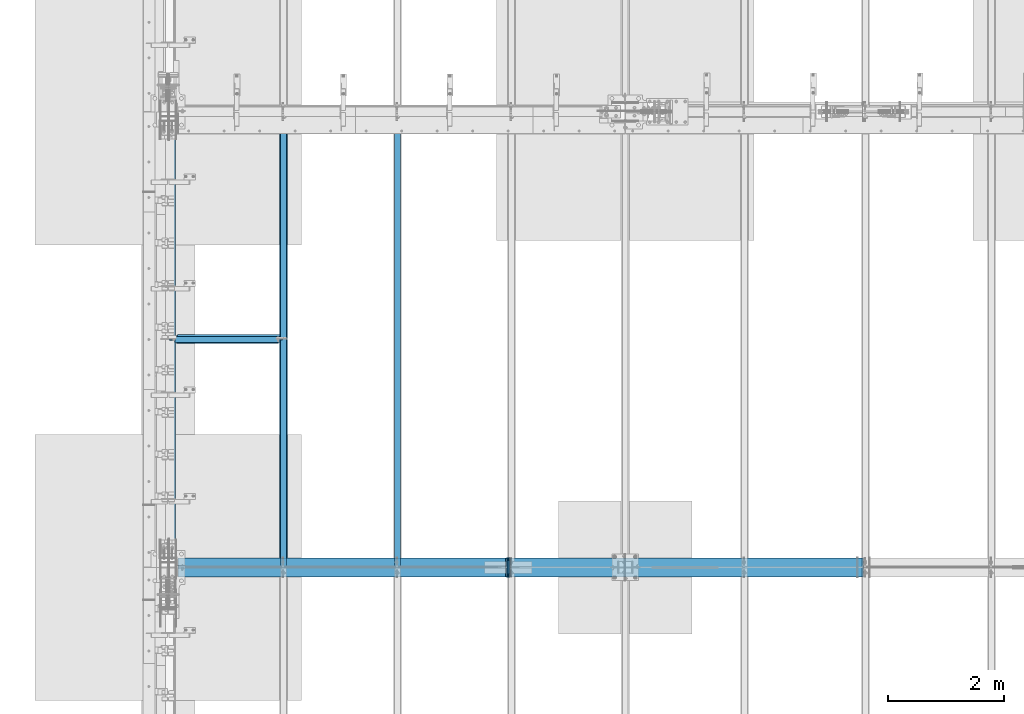
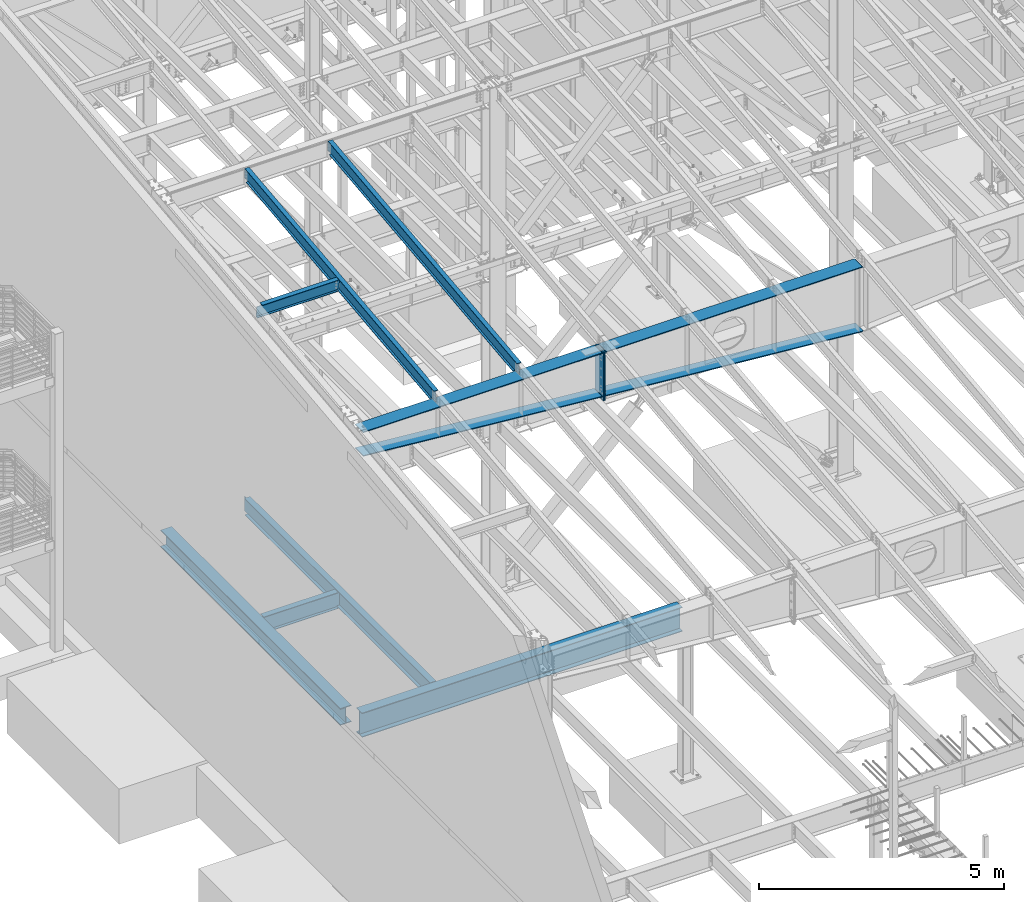
# One storey, part 726 of 1179: 13 beams, 9 elements without a shape of their own.
"""IFC2X3 building model written with IfcOpenShell, lengths in millimetres."""

from ifc_helpers import new_model, si_unit, frame, origin_with_axes, place, context, subcontext, project, spatial, faceted_brep, material, type_object, element, aggregate, save


model = new_model("IFC2X3")

# Units and contexts
model_context = context("Model", 3, precision=1e-05, world=origin_with_axes())
body_context = subcontext(model_context, "Body", "Model", "MODEL_VIEW")
ifc_project = project(units=[si_unit("LENGTHUNIT", "METRE", prefix="MILLI"), si_unit("AREAUNIT", "SQUARE_METRE"), si_unit("VOLUMEUNIT", "CUBIC_METRE"), si_unit("MASSUNIT", "GRAM", prefix="KILO"), si_unit("TIMEUNIT", "SECOND"), si_unit("PLANEANGLEUNIT", "RADIAN"), si_unit("SOLIDANGLEUNIT", "STERADIAN"), si_unit("THERMODYNAMICTEMPERATUREUNIT", "DEGREE_CELSIUS"), si_unit("LUMINOUSINTENSITYUNIT", "LUMEN")], contexts=[model_context])

# Site, building, storey
site_placement = place(None, origin_with_axes())
site = spatial("IfcSite", under=ifc_project, at=site_placement, CompositionType="ELEMENT")
building_placement = place(site_placement, origin_with_axes())
building = spatial("IfcBuilding", under=site, at=building_placement, Name="Undefined", CompositionType="ELEMENT")
storey_placement = place(building_placement, origin_with_axes())
storey = spatial("IfcBuildingStorey", under=building, at=storey_placement, Name="Undefined", CompositionType="ELEMENT", Elevation=0.0)

# Assembly, beam
assembly_1_placement = place(storey_placement, origin_with_axes())
assembly_1 = element("IfcElementAssembly", 1, at=assembly_1_placement, inside=storey, Name="BEAM", AssemblyPlace="NOTDEFINED", PredefinedType="RIGID_FRAME")
ifc_material_1 = material(Name="STEEL/A992")
beam_type_1 = type_object("IfcBeamType", Name="W16X31", PredefinedType="NOTDEFINED")
beam_1_placement = place(assembly_1_placement, frame((431.800000000002, 23139.4, 3900.4875), z_axis=(0.0, 0.0, 1.0), x_axis=(1.0, 0.0, 0.0)))
beam_1 = element("IfcBeam", 2, at=beam_1_placement, type_object=beam_type_1, material=ifc_material_1, Name="BEAM", ObjectType="W16X31", context=body_context, shape_type="Brep", body=[
    faceted_brep([(1898.64985351562, -3.17499999999927, -190.5), (1898.64985351562, -69.8500000000004, -190.5), (1898.64985351562, -69.8500000000004, -201.6125), (1898.64985351562, 69.8500000000004, -201.6125), (1898.64985351562, 69.8500000000004, -190.5), (1898.64985351562, 3.17499999999927, -190.5), (1898.64985351562, 3.17499999999927, -182.562499809264), (1898.64985351562, -3.17499999999927, -182.562499809264), (1899.61658343821, 3.17499999999927, -177.702420291219), (1899.61658343821, -3.17499999999927, -177.702420291219), (1902.36959733869, 3.17499999999927, -173.582243823065), (1902.36959733869, -3.17499999999927, -173.582243823065), (1906.48977380684, 3.17499999999927, -170.829229922587), (1906.48977380684, -3.17499999999927, -170.829229922587), (1911.34985332489, 3.17499999999927, -169.862499999999), (1911.34985332489, -3.17499999999927, -169.862499999999), (1965.32485351562, -3.17499999999927, -169.862499999999), (1965.32485351562, 3.17499999999927, -169.862499999999), (142.081250000001, 3.17499999999927, 190.5), (142.081250000001, 69.8499999999985, 190.5), (1898.64985351562, 69.8500000000004, 190.5), (1898.64985351562, 3.17499999999927, 190.5), (142.08125, -3.17499999999927, -169.862499809266), (142.08125, 3.17499999999927, -169.862499809266), (142.081250000001, 3.17499999999927, -190.5), (142.081250000001, 69.8499999999985, -190.5), (142.081250000001, 69.8499999999985, -201.6125), (142.081250000001, -69.8499999999985, -201.6125), (142.081250000001, -69.8499999999985, -190.5), (142.081250000001, -3.17499999999927, -190.5), (141.114520077412, -3.17499999999927, -165.00242029122), (141.114520077412, 3.17499999999927, -165.00242029122), (138.361506176934, -3.17499999999927, -160.882243823066), (138.361506176934, 3.17499999999927, -160.882243823066), (134.24132970878, -3.17499999999927, -158.129229922588), (134.24132970878, 3.17499999999927, -158.129229922588), (129.381250190735, -3.17499999999927, -157.1625), (129.381250190735, 3.17499999999927, -157.1625), (18.2562499999996, -3.17499999999927, -157.1625), (18.2562499999996, 3.17499999999927, -157.1625), (18.2562499999996, -3.17499999999927, 157.1625), (18.2562499999996, 3.17499999999927, 157.1625), (129.381250190735, -3.17499999999927, 157.1625), (129.381250190735, 3.17499999999927, 157.1625), (134.24132970878, -3.17499999999927, 158.129229922588), (134.24132970878, 3.17499999999927, 158.129229922588), (138.361506176934, -3.17499999999927, 160.882243823066), (138.361506176934, 3.17499999999927, 160.882243823066), (141.114520077412, -3.17499999999927, 165.00242029122), (141.114520077412, 3.17499999999927, 165.00242029122), (142.08125, -3.17499999999927, 169.862499809265), (142.08125, 3.17499999999927, 169.862499809265), (142.081250000001, -69.8499999999985, 201.6125), (142.081250000001, 69.8499999999985, 201.6125), (142.081250000001, -3.17499999999927, 190.5), (142.081250000001, -69.8499999999985, 190.5), (1898.64985351562, -3.17499999999927, 190.5), (1898.64985351562, -69.8500000000004, 190.5), (1898.64985351562, -69.8500000000004, 201.6125), (1898.64985351562, 69.8500000000004, 201.6125), (1898.64985351562, -3.17499999999927, 182.562499809266), (1898.64985351562, 3.17499999999927, 182.562499809266), (1899.61658343821, -3.17499999999927, 177.70242029122), (1899.61658343821, 3.17499999999927, 177.70242029122), (1902.36959733869, -3.17499999999927, 173.582243823067), (1902.36959733869, 3.17499999999927, 173.582243823067), (1906.48977380684, -3.17499999999927, 170.829229922589), (1906.48977380684, 3.17499999999927, 170.829229922589), (1911.34985332489, -3.17499999999927, 169.862500000001), (1911.34985332489, 3.17499999999927, 169.862500000001), (1965.32485351562, -3.17499999999927, 169.862500000001), (1965.32485351562, 3.17499999999927, 169.862500000001)], [[[0, 1, 2, 3, 4, 5, 6, 7]], [[7, 6, 8, 9]], [[9, 8, 10, 11]], [[11, 10, 12, 13]], [[13, 12, 14, 15]], [[16, 15, 14, 17]], [[18, 19, 20, 21]], [[22, 23, 24, 25, 26, 27, 28, 29]], [[30, 31, 23, 22]], [[32, 33, 31, 30]], [[34, 35, 33, 32]], [[36, 37, 35, 34]], [[38, 39, 37, 36]], [[40, 41, 39, 38]], [[42, 43, 41, 40]], [[44, 45, 43, 42]], [[46, 47, 45, 44]], [[48, 49, 47, 46]], [[50, 51, 49, 48]], [[52, 53, 19, 18, 51, 50, 54, 55]], [[55, 54, 56, 57]], [[52, 55, 57, 58]], [[53, 52, 58, 59]], [[19, 53, 59, 20]], [[58, 57, 56, 60, 61, 21, 20, 59]], [[62, 63, 61, 60]], [[64, 65, 63, 62]], [[66, 67, 65, 64]], [[68, 69, 67, 66]], [[70, 71, 69, 68]], [[71, 70, 16, 17]], [[12, 10, 8, 6, 5, 24, 23, 31, 33, 35, 37, 39, 41, 43, 45, 47, 49, 51, 18, 21, 61, 63, 65, 67, 69, 71, 17, 14]], [[25, 24, 5, 4]], [[26, 25, 4, 3]], [[27, 26, 3, 2]], [[28, 27, 2, 1]], [[29, 28, 1, 0]], [[70, 68, 66, 64, 62, 60, 56, 54, 50, 48, 46, 44, 42, 40, 38, 36, 34, 32, 30, 22, 29, 0, 7, 9, 11, 13, 15, 16]]]),
])
aggregate(assembly_1, [beam_1])

assembly_2_placement = place(storey_placement, origin_with_axes())
assembly_2 = element("IfcElementAssembly", 3, at=assembly_2_placement, inside=storey, Name="BEAM", AssemblyPlace="NOTDEFINED", PredefinedType="RIGID_FRAME")
beam_2_placement = place(assembly_2_placement, frame((2412.99985351563, 19227.8, 3900.4875), z_axis=(0.0, 0.0, 1.0), x_axis=(0.0, 1.0, 0.0)))
beam_2 = element("IfcBeam", 4, at=beam_2_placement, type_object=beam_type_1, material=ifc_material_1, Name="BEAM", ObjectType="W16X31", context=body_context, shape_type="Brep", body=[
    faceted_brep([(113.506251936145, -3.17499999997744, 169.8625), (113.506251936145, 3.17496422017757, 169.8625), (18.2562514952835, 3.17499999999927, 169.8625), (18.2562514952835, -3.17499999999927, 169.8625), (118.366331454192, -3.17499999997926, 170.829229922588), (118.366331454192, 3.17496349569046, 170.829229922588), (122.486507922345, -3.17499999997744, 173.582243823066), (122.486507922345, 3.17496143253265, 173.582243823066), (125.239521822827, -3.17499999997563, 177.70242029122), (125.239521822819, 3.17495834479632, 177.70242029122), (126.206251745411, -3.17499999997744, 182.562499809265), (126.206251745411, 3.1749547025629, 182.562499809265), (126.206251745432, -69.8499999999767, 201.6125), (126.206251745396, 69.850000000024, 201.6125), (126.206251745396, 69.850000000024, 190.5), (126.206251745418, 3.17500000002292, 190.5), (126.206251745411, -3.17499999997744, 190.5), (126.206251745432, -69.8499999999767, 190.5), (7677.15000000001, 3.17499999999927, -190.5), (7677.15000000001, 69.8499999999985, -190.5), (145.256250000001, 69.8499999999985, -190.5), (145.256250000001, 3.17549991607666, -190.5), (18.2562500000006, -3.17500000000291, -190.5), (18.2562500000006, -69.8499999999985, -190.5), (7804.15, -69.8499999999985, -190.5), (7804.15, -3.17499999999927, -190.5), (18.2562500000006, -69.8499999999985, -201.612499999999), (7804.15, -69.8499999999985, -201.6125), (7677.15000000001, 69.8499999999985, -201.6125), (7677.15000000001, 3.17549991607666, -201.6125), (7804.15, 3.17549991607666, -201.6125), (18.2562500000006, 3.17549991607666, -201.612499999999), (145.256250000001, 3.17549991607666, -201.612499999999), (145.256250000001, 69.8499999999985, -201.612499999999), (18.2562500000006, 3.17500000000291, -190.5), (7804.15, 3.17499999999927, -190.5), (7804.15, 3.17499999999927, 169.8625), (7804.15, -3.17499999999927, 169.8625), (7708.89999980925, 3.17499999999927, 169.8625), (7708.89999980925, -3.17499999999927, 169.8625), (7704.03992029121, 3.17499999999927, 170.829229922588), (7704.03992029121, -3.17499999999927, 170.829229922588), (7699.91974382305, 3.17499999999927, 173.582243823066), (7699.91974382305, -3.17499999999927, 173.582243823066), (7697.16672992258, 3.17499999999927, 177.70242029122), (7697.16672992258, -3.17499999999927, 177.70242029122), (7696.19999999999, 3.17499999999927, 182.562499809265), (7696.19999999999, -3.17499999999927, 182.562499809265), (7696.19999999999, -69.8499999999985, 201.6125), (7696.19999999999, -69.8499999999985, 190.5), (7696.19999999999, -3.17499999999927, 190.5), (7696.19999999999, 3.17499999999927, 190.5), (7696.19999999999, 69.8499999999985, 190.5), (7696.19999999999, 69.8499999999985, 201.6125)], [[[0, 1, 2, 3]], [[4, 5, 1, 0]], [[6, 7, 5, 4]], [[8, 9, 7, 6]], [[10, 11, 9, 8]], [[12, 13, 14, 15, 11, 10, 16, 17]], [[18, 19, 20, 21]], [[22, 23, 24, 25]], [[23, 26, 27, 24]], [[28, 29, 30, 27, 26, 31, 32, 33]], [[21, 32, 31, 34]], [[20, 33, 32, 21]], [[19, 28, 33, 20]], [[18, 29, 28, 19]], [[35, 30, 29, 18]], [[25, 24, 27, 30, 35, 36, 37]], [[37, 36, 38, 39]], [[39, 38, 40, 41]], [[41, 40, 42, 43]], [[43, 42, 44, 45]], [[45, 44, 46, 47]], [[48, 49, 50, 47, 46, 51, 52, 53]], [[49, 48, 12, 17]], [[50, 49, 17, 16]], [[8, 6, 4, 0, 3, 22, 25, 37, 39, 41, 43, 45, 47, 50, 16, 10]], [[34, 31, 26, 23, 22, 3, 2]], [[51, 46, 44, 42, 40, 38, 36, 35, 18, 21, 34, 2, 1, 5, 7, 9, 11, 15]], [[52, 51, 15, 14]], [[53, 52, 14, 13]], [[48, 53, 13, 12]]]),
])
aggregate(assembly_2, [beam_2])

assembly_3_placement = place(storey_placement, origin_with_axes())
assembly_3 = element("IfcElementAssembly", 5, at=assembly_3_placement, inside=storey, Name="RAFTER BEAM", AssemblyPlace="NOTDEFINED", PredefinedType="RIGID_FRAME")
ifc_material_2 = material(Name="STEEL/A36")
beam_type_2 = type_object("IfcBeamType", PredefinedType="NOTDEFINED")
beam_3_placement = place(assembly_3_placement, frame((6261.1, 19392.8999999987, 10522.74375), z_axis=(0.0, 0.0, 1.0), x_axis=(0.0, -1.0, 0.0)))
beam_3 = element("IfcBeam", 6, at=beam_3_placement, type_object=beam_type_2, material=ifc_material_2, Name="PLATE", context=body_context, shape_type="Brep", body=[
    faceted_brep([(0.0, 12.7000000000007, -604.8375), (0.0, 12.7000000000007, 604.8375), (330.199999998662, 12.7000000000007, 604.8375), (330.199999998662, 12.7000000000007, -604.8375), (0.0, -12.7000000000007, 604.8375), (330.199999998662, -12.7000000000007, 604.8375), (0.0, -12.7000000000007, -604.8375), (330.199999998662, -12.7000000000007, -604.8375)], [[[0, 1, 2, 3]], [[1, 4, 5, 2]], [[4, 6, 7, 5]], [[6, 0, 3, 7]], [[5, 7, 3, 2]], [[6, 4, 1, 0]]]),
])

assembly_4_placement = place(storey_placement, origin_with_axes())
assembly_4 = element("IfcElementAssembly", 7, at=assembly_4_placement, inside=storey, Name="RAFTER BEAM", AssemblyPlace="NOTDEFINED", PredefinedType="RIGID_FRAME")
beam_4_placement = place(assembly_4_placement, frame((6286.5, 19392.8999999987, 10522.74375), z_axis=(0.0, 0.0, 1.0), x_axis=(0.0, -1.0, 0.0)))
beam_4 = element("IfcBeam", 8, at=beam_4_placement, type_object=beam_type_2, material=ifc_material_2, Name="PLATE", context=body_context, shape_type="Brep", body=[
    faceted_brep([(0.0, 12.7000000000007, -604.8375), (0.0, 12.7000000000007, 604.8375), (330.199999998662, 12.7000000000007, 604.8375), (330.199999998662, 12.7000000000007, -604.8375), (0.0, -12.7000000000007, 604.8375), (330.199999998662, -12.7000000000007, 604.8375), (0.0, -12.7000000000007, -604.8375), (330.199999998662, -12.7000000000007, -604.8375)], [[[0, 1, 2, 3]], [[1, 4, 5, 2]], [[4, 6, 7, 5]], [[6, 0, 3, 7]], [[5, 7, 3, 2]], [[6, 4, 1, 0]]]),
])

# Beam
beam_type_3 = type_object("IfcBeamType", PredefinedType="NOTDEFINED")
beam_5_placement = place(assembly_3_placement, frame((600.692587263406, 19227.8, 10529.2164037786), z_axis=(0.0, 1.0, 0.0), x_axis=(0.996183710890709, 0.0, -0.0872812359904244)))
beam_5 = element("IfcBeam", 9, at=beam_5_placement, type_object=beam_type_3, material=ifc_material_2, Name="PLATE", context=body_context, shape_type="Brep", body=[
    faceted_brep([(5670.3221448979, 11.172430163635, 165.1), (5643.908580592, -11.1125000006832, 165.1), (5643.908580592, -11.1125000006832, -165.1), (5670.31689408045, 11.1124999993244, -165.1), (1.66062363859965e-09, -11.1125000000084, -165.1), (1.66062363859965e-09, -11.1125000000084, 165.1), (1.94725676632936, 11.1125000000065, 165.1), (1.94725676632936, 11.1125000000065, -165.1)], [[[0, 1, 2, 3]], [[4, 5, 6, 7]], [[7, 6, 0, 3]], [[4, 7, 3, 2]], [[5, 4, 2, 1]], [[6, 5, 1, 0]]]),
])

beam_6_placement = place(assembly_3_placement, frame((601.662500000002, 19227.7999999987, 11116.4687496185), z_axis=(0.0, -1.0, 0.0), x_axis=(1.0, 0.0, 0.0)))
beam_6 = element("IfcBeam", 10, at=beam_6_placement, type_object=beam_type_3, material=ifc_material_2, Name="PLATE", context=body_context, shape_type="Brep", body=[
    faceted_brep([(5646.7375, -11.1124999999993, 165.1), (5646.7375, -11.1124999999993, -165.1), (5624.51249961853, 11.1124999999993, -165.1), (5624.51249961853, 11.1124999999993, 165.1), (1.66062363859965e-09, -11.1125000000084, -165.1), (1.66062363859965e-09, -11.1125000000084, 165.1), (0.0, 11.1124999999993, 165.1), (0.0, 11.1124999999993, -165.1)], [[[0, 1, 2, 3]], [[4, 5, 6, 7]], [[6, 5, 0, 3]], [[7, 6, 3, 2]], [[4, 7, 2, 1]], [[5, 4, 1, 0]]]),
])

aggregate(assembly_3, [beam_3, beam_5, beam_6])

beam_7_placement = place(assembly_4_placement, frame((6272.85711370745, 19227.8000000028, 10032.2463234305), z_axis=(0.0, 1.0, 0.0), x_axis=(0.996393807714311, 0.0, -0.0848491599756718)))
beam_7 = element("IfcBeam", 11, at=beam_7_placement, type_object=beam_type_3, material=ifc_material_2, Name="PLATE", context=body_context, shape_type="Brep", body=[
    faceted_brep([(6118.06175688711, -11.1260574296557, 165.1), (6118.06324270278, -11.1125000015909, -165.1), (6099.33128163823, 11.1124999984149, -165.1), (6099.33128163823, 11.1124999984149, 165.1), (46.0705669150266, -11.1125236432727, 165.1), (27.3845310142515, 11.112499999992, 165.1), (27.3845310142515, 11.112499999992, -165.1), (46.0705669150275, -11.1125000000138, -165.1)], [[[0, 1, 2, 3]], [[4, 5, 6, 7]], [[5, 4, 0, 3]], [[6, 5, 3, 2]], [[7, 6, 2, 1]], [[4, 7, 1, 0]]]),
])

beam_8_placement = place(assembly_4_placement, frame((6273.8, 19227.7999999987, 11116.4687496185), z_axis=(0.0, -1.0, 0.0), x_axis=(1.0, 0.0, 0.0)))
beam_8 = element("IfcBeam", 12, at=beam_8_placement, type_object=beam_type_3, material=ifc_material_2, Name="PLATE", context=body_context, shape_type="Brep", body=[
    faceted_brep([(47.6250003814685, 11.1125003814705, 165.1), (47.6250003814685, 11.1124999999993, -165.1), (25.3999999999987, -11.1124999999993, -165.1), (25.3999999999987, -11.1124999999993, 165.1), (6096.0, -11.1124999999993, 165.1), (6096.0, -11.1124999999993, -165.1), (6073.77499961853, 11.1124999999993, -165.1), (6073.77499961853, 11.1124999999993, 165.1)], [[[0, 1, 2, 3]], [[4, 5, 6, 7]], [[4, 7, 0, 3]], [[5, 4, 3, 2]], [[6, 5, 2, 1]], [[7, 6, 1, 0]]]),
])

aggregate(assembly_4, [beam_4, beam_7, beam_8])

# Assembly, beam
assembly_5_placement = place(storey_placement, origin_with_axes())
assembly_5 = element("IfcElementAssembly", 13, at=assembly_5_placement, inside=storey, Name="BEAM", AssemblyPlace="NOTDEFINED", PredefinedType="RIGID_FRAME")
beam_type_4 = type_object("IfcBeamType", Name="W12X22", PredefinedType="NOTDEFINED")
beam_9_placement = place(assembly_5_placement, frame((431.800000000002, 23156.8779321476, 11707.011532693), z_axis=(0.0, -0.112284087038017, 0.993676146336441), x_axis=(1.0, 0.0, 0.0)))
beam_9 = element("IfcBeam", 14, at=beam_9_placement, type_object=beam_type_4, material=ifc_material_1, Name="BEAM", ObjectType="W12X22", context=body_context, shape_type="Brep", body=[
    faceted_brep([(1917.7, -3.1750000000502, -144.462499999914), (1917.7, -50.8000000000247, -144.462499999896), (1917.7, -50.8000000000284, -155.574999999892), (1917.7, 50.7999999999156, -155.574999999932), (1917.7, 50.7999999999192, -144.46249999994), (1917.7, 3.17499999869324, -144.462499999918), (1917.7, 3.17499998151106, -142.874999810523), (1917.7, -3.17500000004657, -142.874999810521), (1918.66672992259, 3.17499998191852, -138.014920292486), (1918.66672992259, -3.17500000004657, -138.014920292482), (1921.41974382307, 3.17499998226413, -133.894743824339), (1921.41974382307, -3.17500000004293, -133.894743824334), (1925.53992029122, 3.17499998249332, -131.141729923864), (1925.53992029122, -3.17500000004293, -131.141729923862), (1930.39999980926, 3.17499998257699, -130.175000001278), (1930.39999980926, -3.17500000004293, -130.175000001276), (1965.325, -3.17500000004293, -130.175000001276), (1965.325, 3.17499999995198, -130.175000001278), (121.44375, 3.17500000006476, 144.462499999918), (121.44375, 50.8000000000357, 144.4624999999), (1917.7, 50.8000000000357, 144.4624999999), (1917.7, 3.17500000006476, 144.462499999918), (159.54375, 50.7999999999192, -144.46249999994), (159.54375, 50.7999999999156, -155.574999999932), (159.54375, 3.17499995235266, -155.574999999913), (159.54375, 3.17499995235994, -144.462499999918), (19.8437500000002, 3.17499995235266, -155.574999999913), (19.8437500000002, 3.17499999994834, -144.46249999992), (19.8437500000002, -50.8000000000284, -155.574999999892), (19.8437500000002, -50.8000000000247, -144.462499999896), (19.8437500000002, -3.1750000000502, -144.462499999914), (19.8437500000002, -3.1749999999447, 117.474999998307), (19.8437500000002, 3.17500000005384, 117.474999998303), (108.743750190735, -3.1749999999447, 117.474999998307), (108.743750190735, 3.17500000199652, 117.474999998303), (113.603829708781, -3.1749999999447, 118.441729920891), (113.603829708781, 3.17500000207292, 118.441729920887), (117.724006176934, -3.1749999999447, 121.194743821365), (117.724006176934, 3.17500000229848, 121.194743821363), (120.477020077412, -3.17499999993743, 125.314920289511), (120.477020077412, 3.17500000264045, 125.314920289509), (121.44375, -3.17499999993743, 130.174999807548), (121.44375, 3.17500000304426, 130.174999807547), (121.44375, -50.799999999901, 155.574999999935), (121.44375, 50.8000000000429, 155.574999999893), (121.44375, -3.17499999993379, 144.462499999923), (121.44375, -50.7999999999047, 144.462499999941), (1917.7, -3.17499999993379, 144.462499999923), (1917.7, -50.7999999999047, 144.462499999941), (1917.7, -50.799999999901, 155.574999999935), (1917.7, 50.8000000000429, 155.574999999893), (1917.7, -3.17499999993015, 142.874999807531), (1917.7, 3.17500000523796, 142.874999807529), (1918.66672992259, -3.17499999993379, 138.014920289494), (1918.66672992259, 3.17500000483415, 138.01492028949), (1921.41974382307, -3.17499999993743, 133.894743821347), (1921.41974382307, 3.17500000449218, 133.894743821345), (1925.53992029122, -3.17499999993379, 131.141729920873), (1925.53992029122, 3.17500000425935, 131.141729920872), (1930.39999980926, -3.17499999994106, 130.174999998288), (1930.39999980926, 3.17500000417931, 130.174999998286), (1965.325, -3.17499999994106, 130.174999998288), (1965.325, 3.17500000005748, 130.174999998284)], [[[0, 1, 2, 3, 4, 5, 6, 7]], [[7, 6, 8, 9]], [[9, 8, 10, 11]], [[11, 10, 12, 13]], [[13, 12, 14, 15]], [[16, 15, 14, 17]], [[18, 19, 20, 21]], [[22, 23, 24, 25]], [[25, 24, 26, 27]], [[27, 26, 28, 29, 30, 31, 32]], [[33, 34, 32, 31]], [[35, 36, 34, 33]], [[37, 38, 36, 35]], [[39, 40, 38, 37]], [[41, 42, 40, 39]], [[43, 44, 19, 18, 42, 41, 45, 46]], [[46, 45, 47, 48]], [[43, 46, 48, 49]], [[44, 43, 49, 50]], [[19, 44, 50, 20]], [[49, 48, 47, 51, 52, 21, 20, 50]], [[53, 54, 52, 51]], [[55, 56, 54, 53]], [[57, 58, 56, 55]], [[59, 60, 58, 57]], [[61, 62, 60, 59]], [[62, 61, 16, 17]], [[12, 10, 8, 6, 5, 25, 27, 32, 34, 36, 38, 40, 42, 18, 21, 52, 54, 56, 58, 60, 62, 17, 14]], [[22, 25, 5, 4]], [[23, 22, 4, 3]], [[28, 26, 24, 23, 3, 2]], [[29, 28, 2, 1]], [[30, 29, 1, 0]], [[61, 59, 57, 55, 53, 51, 47, 45, 41, 39, 37, 35, 33, 31, 30, 0, 7, 9, 11, 13, 15, 16]]]),
])
aggregate(assembly_5, [beam_9])

assembly_6_placement = place(storey_placement, origin_with_axes())
assembly_6 = element("IfcElementAssembly", 15, at=assembly_6_placement, inside=storey, Name="BEAM", AssemblyPlace="NOTDEFINED", PredefinedType="RIGID_FRAME")
beam_10_placement = place(assembly_6_placement, frame((4368.8, 19245.2779321397, 11265.0059190149), z_axis=(0.0, -0.112284087038017, 0.993676146336441), x_axis=(0.0, 0.993676146336441, 0.112284087038017)))
beam_10 = element("IfcBeam", 16, at=beam_10_placement, type_object=beam_type_4, material=ifc_material_1, Name="BEAM", ObjectType="W12X22", context=body_context, shape_type="Brep", body=[
    faceted_brep([(7676.8057846648, 3.17499999999927, -144.462500003032), (7676.80578466482, 3.17490308365814, -155.575000003026), (7676.80577856895, 50.7999999999993, -155.575000003026), (7676.80577856896, 50.7999999999993, -144.462500003034), (7820.7019525921, 3.17499999999927, -144.462500003092), (7819.44625482597, 3.17492134140048, -155.575000003084), (5.12531926095107, 3.17499999999927, 144.46249999992), (5.12531926095107, 50.7999999999993, 144.46249999992), (7757.4939140051, 50.7999999999993, 144.462499996773), (7757.4939140051, 3.17499999999927, 144.462499996773), (5.12531926095107, -3.17499999999927, 144.46249999992), (5.12531926095107, -50.7999999999993, 144.46249999992), (6.38101702707718, -50.7999999999993, 155.574999999912), (6.38101702707718, 50.7999999999993, 155.574999999912), (-25.0621566261689, 3.17499999999927, -122.686438896275), (-25.0621566261689, -3.17499999999927, -122.686438896275), (145.312894957096, 3.17499999999927, -141.93859400049), (145.312894957096, -3.17499999999927, -141.93859400049), (145.027696926005, -3.17499999999927, -144.462499999976), (145.027696926005, -50.7999999999993, -144.462499999976), (7676.805791578, -50.7999999999993, -144.462500003034), (7676.805785482, -3.17499999999927, -144.462500003032), (145.027696926005, 3.17499999999927, -144.462499999976), (145.027696926005, 50.7999999999993, -144.462499999976), (143.771999161854, 50.7999999999993, -155.574999999972), (143.771999161854, -50.7999999999993, -155.574999999972), (7676.805791578, -50.7999999999993, -155.575000003026), (7676.80578548203, -3.17509692720705, -155.575000003026), (7820.7019525921, -3.17499999999927, -144.462500003092), (7819.44625482597, -3.17507866903179, -155.575000003084), (7760.28182167741, -3.17499999999927, 99.3123538561285), (7756.49682025474, -3.17499999999927, 102.510588352729), (7754.22384626446, -3.17499999999927, 106.91382908024), (7753.80893939206, -3.17499999999927, 111.851722553385), (7757.4939140051, -3.17499999999927, 144.462499996773), (7821.50556176969, -3.17499999999927, -137.350830916108), (7847.03058449439, -3.17499999999927, 88.5369763886902), (7765.00261837702, -3.17499999999927, 97.8060278004923), (7757.4939140051, -50.7999999999993, 144.462499996773), (7758.74961177122, -50.7999999999993, 155.574999996767), (7758.74961177122, 50.7999999999993, 155.574999996767), (7753.80893939206, 3.17499999999927, 111.851722553385), (7754.22384626446, 3.17499999999927, 106.91382908024), (7756.49682025474, 3.17499999999927, 102.510588352729), (7760.28182167741, 3.17499999999927, 99.3123538561285), (7765.00261837702, 3.17499999999927, 97.8060278004923), (7847.03058449439, 3.17499999999927, 88.5369763886902), (7821.50554925474, 3.17499999999927, -137.350941669098)], [[[0, 1, 2, 3]], [[4, 5, 1, 0]], [[6, 7, 8, 9]], [[10, 11, 12, 13, 7, 6, 14, 15]], [[15, 14, 16, 17]], [[18, 19, 20, 21]], [[17, 16, 22, 23, 24, 25, 19, 18]], [[19, 25, 26, 20]], [[20, 26, 27, 21]], [[28, 21, 27, 29]], [[30, 31, 32, 33, 34, 10, 15, 17, 18, 21, 28, 35, 36, 37]], [[11, 10, 34, 38]], [[12, 11, 38, 39]], [[13, 12, 39, 40]], [[7, 13, 40, 8]], [[39, 38, 34, 33, 41, 9, 8, 40]], [[32, 42, 41, 33]], [[31, 43, 42, 32]], [[30, 44, 43, 31]], [[37, 45, 44, 30]], [[36, 46, 45, 37]], [[47, 4, 0, 22, 16, 14, 6, 9, 41, 42, 43, 44, 45, 46]], [[23, 22, 0, 3]], [[24, 23, 3, 2]], [[29, 27, 26, 25, 24, 2, 1, 5]], [[47, 46, 36, 35, 28, 29, 5, 4]]]),
])
aggregate(assembly_6, [beam_10])

assembly_7_placement = place(storey_placement, origin_with_axes())
assembly_7 = element("IfcElementAssembly", 17, at=assembly_7_placement, inside=storey, Name="BEAM", AssemblyPlace="NOTDEFINED", PredefinedType="RIGID_FRAME")
beam_11_placement = place(assembly_7_placement, frame((2413.0, 19245.2779321397, 11265.0059190149), z_axis=(0.0, -0.112284087038017, 0.993676146336441), x_axis=(0.0, 0.993676146336441, 0.112284087038017)))
beam_11 = element("IfcBeam", 18, at=beam_11_placement, type_object=beam_type_4, material=ifc_material_1, Name="BEAM", ObjectType="W12X22", context=body_context, shape_type="Brep", body=[
    faceted_brep([(7676.8057846648, 3.17499999999927, -144.462500003032), (7676.80578466482, 3.17490308365814, -155.575000003026), (7676.80577856895, 50.7999999999993, -155.575000003026), (7676.80577856896, 50.7999999999993, -144.462500003034), (7820.7019525921, 3.17499999999927, -144.462500003092), (7819.44625482597, 3.17492134140048, -155.575000003084), (5.12531926095107, 3.17499999999927, 144.46249999992), (5.12531926095107, 50.7999999999993, 144.46249999992), (7757.4939140051, 50.7999999999993, 144.462499996773), (7757.4939140051, 3.17499999999927, 144.462499996773), (5.12531926095107, -3.17499999999927, 144.46249999992), (5.12531926095107, -50.7999999999993, 144.46249999992), (6.38101702707718, -50.7999999999993, 155.574999999912), (6.38101702707718, 50.7999999999993, 155.574999999912), (-25.0621566261689, 3.17499999999927, -122.686438896275), (-25.0621566261689, -3.17499999999927, -122.686438896275), (145.312894957096, 3.17499999999927, -141.93859400049), (145.312894957096, -3.17499999999927, -141.93859400049), (145.027696926005, -3.17499999999927, -144.462499999976), (145.027696926005, -50.7999999999993, -144.462499999976), (7676.805791578, -50.7999999999993, -144.462500003034), (7676.805785482, -3.17499999999927, -144.462500003032), (145.027696926005, 3.17499999999927, -144.462499999976), (145.027696926005, 50.7999999999993, -144.462499999976), (143.771999161854, 50.7999999999993, -155.574999999972), (143.771999161854, -50.7999999999993, -155.574999999972), (7676.805791578, -50.7999999999993, -155.575000003026), (7676.80578548203, -3.17509692720705, -155.575000003026), (7820.7019525921, -3.17499999999927, -144.462500003092), (7819.44625482597, -3.17507866903179, -155.575000003084), (7760.28182167741, -3.17499999999927, 99.3123538561285), (7756.49682025474, -3.17499999999927, 102.510588352729), (7754.22384626446, -3.17499999999927, 106.91382908024), (7753.80893939206, -3.17499999999927, 111.851722553385), (7757.4939140051, -3.17499999999927, 144.462499996773), (7821.50556176969, -3.17499999999927, -137.350830916108), (7847.03058449439, -3.17499999999927, 88.5369763886902), (7765.00261837702, -3.17499999999927, 97.8060278004923), (7757.4939140051, -50.7999999999993, 144.462499996773), (7758.74961177122, -50.7999999999993, 155.574999996767), (7758.74961177122, 50.7999999999993, 155.574999996767), (7753.80893939206, 3.17499999999927, 111.851722553385), (7754.22384626446, 3.17499999999927, 106.91382908024), (7756.49682025474, 3.17499999999927, 102.510588352729), (7760.28182167741, 3.17499999999927, 99.3123538561285), (7765.00261837702, 3.17499999999927, 97.8060278004923), (7847.03058449439, 3.17499999999927, 88.5369763886902), (7821.50554925474, 3.17499999999927, -137.350941669098)], [[[0, 1, 2, 3]], [[4, 5, 1, 0]], [[6, 7, 8, 9]], [[10, 11, 12, 13, 7, 6, 14, 15]], [[15, 14, 16, 17]], [[18, 19, 20, 21]], [[17, 16, 22, 23, 24, 25, 19, 18]], [[19, 25, 26, 20]], [[20, 26, 27, 21]], [[28, 21, 27, 29]], [[30, 31, 32, 33, 34, 10, 15, 17, 18, 21, 28, 35, 36, 37]], [[11, 10, 34, 38]], [[12, 11, 38, 39]], [[13, 12, 39, 40]], [[7, 13, 40, 8]], [[39, 38, 34, 33, 41, 9, 8, 40]], [[32, 42, 41, 33]], [[31, 43, 42, 32]], [[30, 44, 43, 31]], [[37, 45, 44, 30]], [[36, 46, 45, 37]], [[47, 4, 0, 22, 16, 14, 6, 9, 41, 42, 43, 44, 45, 46]], [[23, 22, 0, 3]], [[24, 23, 3, 2]], [[29, 27, 26, 25, 24, 2, 1, 5]], [[47, 46, 36, 35, 28, 29, 5, 4]]]),
])
aggregate(assembly_7, [beam_11])

assembly_8_placement = place(storey_placement, origin_with_axes())
assembly_8 = element("IfcElementAssembly", 19, at=assembly_8_placement, inside=storey, Name="BEAM", AssemblyPlace="NOTDEFINED", PredefinedType="RIGID_FRAME")
beam_type_5 = type_object("IfcBeamType", Name="W16X77", PredefinedType="NOTDEFINED")
beam_12_placement = place(assembly_8_placement, frame((431.800000000002, 19227.8, 3892.55), z_axis=(0.0, 0.0, 1.0), x_axis=(0.0, 1.0, 0.0)))
beam_12 = element("IfcBeam", 20, at=beam_12_placement, type_object=beam_type_5, material=ifc_material_1, Name="BEAM", ObjectType="W16X77", context=body_context, shape_type="Brep", body=[
    faceted_brep([(247.650000000001, -130.174999999999, -209.55), (247.650000000001, 130.174999999999, -209.55), (7575.55, 130.174999999999, -209.55), (7575.55, -130.174999999999, -209.55), (247.650000000001, -130.174999999999, -190.5), (247.649999999994, -5.55624999999998, -190.5), (247.650000000001, -5.55624999999998, -146.789999999991), (247.650000000001, -5.55624999999998, 159.490000000113), (247.649999999994, -5.55624999999998, 190.5), (247.650000000001, -130.174999999999, 190.5), (247.650000000001, -130.174999999999, 209.55), (247.650000000001, 130.174999999999, 209.55), (247.650000000001, 130.174999999999, 190.5), (247.649999999994, 5.55624999999998, 190.5), (247.649999999994, 5.55624999999998, -190.5), (247.650000000001, 130.174999999999, -190.5), (7575.55, -130.174999999999, -190.5), (7575.55, -5.55625000000146, -190.5), (7575.55, -5.55624999999998, -146.789999999991), (7575.55, -5.55624999999998, 159.490000000113), (7575.55, -5.55625000000146, 190.5), (7575.55, -130.174999999999, 190.5), (7575.55, -130.174999999999, 209.55), (7575.55, 130.174999999999, 209.55), (7575.55, 130.174999999999, 190.5), (7575.55, 5.55625000000146, 190.5), (7575.55, 5.55625000000146, -190.5), (7575.55, 130.174999999999, -190.5)], [[[0, 1, 2, 3]], [[0, 4, 5, 6, 7, 8, 9, 10, 11, 12, 13, 14, 15, 1]], [[5, 4, 16, 17]], [[8, 7, 6, 5, 17, 18, 19, 20]], [[9, 8, 20, 21]], [[10, 9, 21, 22]], [[11, 10, 22, 23]], [[12, 11, 23, 24]], [[13, 12, 24, 25]], [[14, 13, 25, 26]], [[15, 14, 26, 27]], [[1, 15, 27, 2]], [[26, 25, 24, 23, 22, 21, 20, 19, 18, 17, 16, 3, 2, 27]], [[4, 0, 3, 16]]]),
])
aggregate(assembly_8, [beam_12])

assembly_9_placement = place(storey_placement, origin_with_axes())
assembly_9 = element("IfcElementAssembly", 21, at=assembly_9_placement, inside=storey, Name="BEAM", AssemblyPlace="NOTDEFINED", PredefinedType="RIGID_FRAME")
beam_type_6 = type_object("IfcBeamType", Name="W24X68", PredefinedType="NOTDEFINED")
beam_13_placement = place(assembly_9_placement, frame((431.800000000002, 19227.8, 3800.475), z_axis=(0.0, 0.0, 1.0), x_axis=(1.0, 0.0, 0.0)))
beam_13 = element("IfcBeam", 22, at=beam_13_placement, type_object=beam_type_6, material=ifc_material_1, Name="BEAM", ObjectType="W24X68", context=body_context, shape_type="Brep", body=[
    faceted_brep([(169.8625, -114.299999999999, -301.625), (169.8625, 114.299999999999, -301.625), (7710.4875, 114.299999999999, -301.625), (7710.4875, -114.299999999999, -301.625), (169.8625, -114.299999999999, -287.3375), (169.8625, -5.55625000000146, -287.3375), (169.8625, -5.55625000000146, 287.3375), (169.8625, -114.299999999999, 287.3375), (169.8625, -114.299999999999, 301.625), (169.8625, 114.299999999999, 301.625), (169.8625, 114.299999999999, 287.3375), (169.8625, 5.55625000000146, 287.3375), (169.8625, 5.55625000000146, -287.3375), (169.8625, 114.299999999999, -287.3375), (7710.4875, -114.299999999999, -287.3375), (7710.4875, -5.55625000000146, -287.3375), (7710.4875, -5.55625000000146, 287.3375), (7710.4875, -114.299999999999, 287.3375), (7710.4875, -114.299999999999, 301.625), (7710.4875, 114.299999999999, 301.625), (7710.4875, 114.299999999999, 287.3375), (7710.4875, 5.55625000000146, 287.3375), (7710.4875, 5.55625000000146, -287.3375), (7710.4875, 114.299999999999, -287.3375)], [[[0, 1, 2, 3]], [[0, 4, 5, 6, 7, 8, 9, 10, 11, 12, 13, 1]], [[5, 4, 14, 15]], [[6, 5, 15, 16]], [[7, 6, 16, 17]], [[8, 7, 17, 18]], [[9, 8, 18, 19]], [[10, 9, 19, 20]], [[11, 10, 20, 21]], [[12, 11, 21, 22]], [[13, 12, 22, 23]], [[1, 13, 23, 2]], [[22, 21, 20, 19, 18, 17, 16, 15, 14, 3, 2, 23]], [[4, 0, 3, 14]]]),
])
aggregate(assembly_9, [beam_13])

save(model, "model.ifc")
